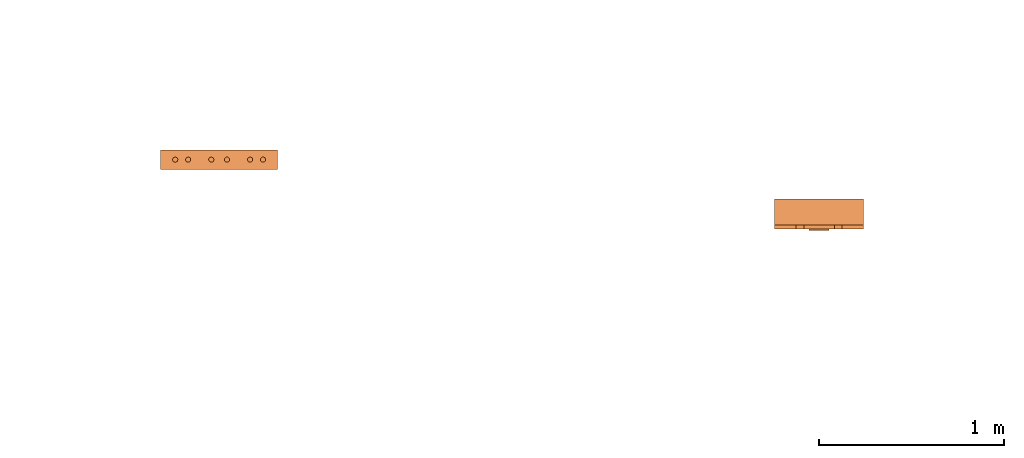
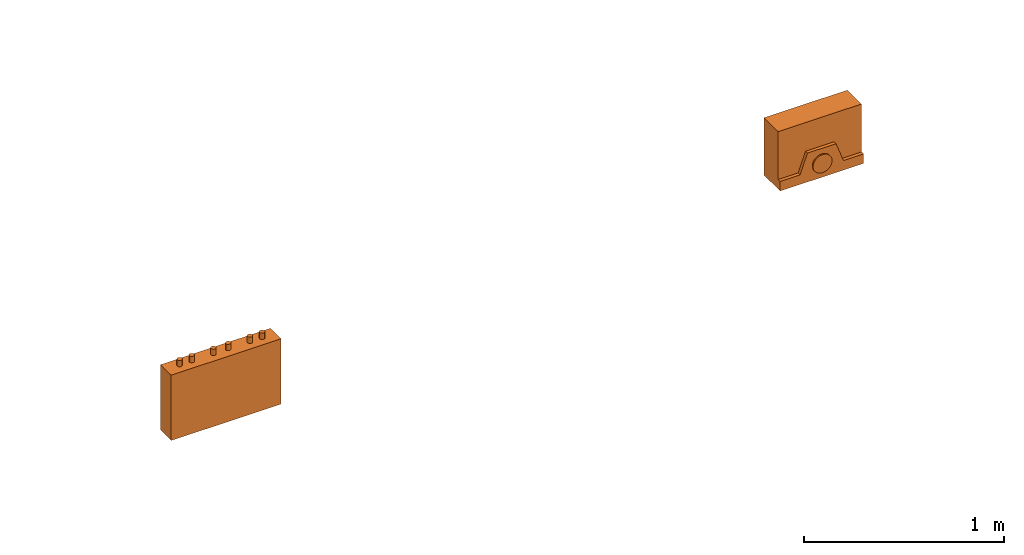
# One storey, part 3 of 5: 2 proxies.
"""IFC2X3 building model written with IfcOpenShell, lengths in millimetres."""

from ifc_helpers import new_model, entity, si_unit, converted_unit, derived_unit, direction, frame, origin, place, context, subcontext, project, spatial, faceted_brep, source, transform, mapped, material, material_list, type_object, type_shapes, element, save


model = new_model("IFC2X3")

# Units and contexts
model_context = context("Model", 3, precision=0.01, world=origin(), true_north=direction((6.12303176911189e-17, 1.0)))
body_context = subcontext(model_context, "Body", "Model", "MODEL_VIEW")
ifc_project = project(units=[si_unit("LENGTHUNIT", "METRE", prefix="MILLI"), si_unit("AREAUNIT", "SQUARE_METRE"), si_unit("VOLUMEUNIT", "CUBIC_METRE"), converted_unit("PLANEANGLEUNIT", "DEGREE", entity("IfcRatioMeasure", 0.0174532925199433), si_unit("PLANEANGLEUNIT", "RADIAN"), dimensions=[0, 0, 0, 0, 0, 0, 0]), si_unit("MASSUNIT", "GRAM", prefix="KILO"), derived_unit("MASSDENSITYUNIT", [(si_unit("MASSUNIT", "GRAM", prefix="KILO"), 1), (si_unit("LENGTHUNIT", "METRE"), -3)]), derived_unit("MOMENTOFINERTIAUNIT", [(si_unit("LENGTHUNIT", "METRE"), 4)]), si_unit("TIMEUNIT", "SECOND"), si_unit("FREQUENCYUNIT", "HERTZ"), si_unit("THERMODYNAMICTEMPERATUREUNIT", "DEGREE_CELSIUS"), derived_unit("THERMALTRANSMITTANCEUNIT", [(si_unit("MASSUNIT", "GRAM", prefix="KILO"), 1), (si_unit("THERMODYNAMICTEMPERATUREUNIT", "KELVIN"), -1), (si_unit("TIMEUNIT", "SECOND"), -3)]), derived_unit("VOLUMETRICFLOWRATEUNIT", [(si_unit("LENGTHUNIT", "METRE"), 3), (si_unit("TIMEUNIT", "SECOND"), -1)]), derived_unit("MASSFLOWRATEUNIT", [(si_unit("MASSUNIT", "GRAM", prefix="KILO"), 1), (si_unit("TIMEUNIT", "SECOND"), -1)]), derived_unit("ROTATIONALFREQUENCYUNIT", [(si_unit("TIMEUNIT", "SECOND"), -1)]), si_unit("ELECTRICCURRENTUNIT", "AMPERE"), si_unit("ELECTRICVOLTAGEUNIT", "VOLT"), si_unit("POWERUNIT", "WATT"), si_unit("FORCEUNIT", "NEWTON", prefix="KILO"), si_unit("ILLUMINANCEUNIT", "LUX"), si_unit("LUMINOUSFLUXUNIT", "LUMEN"), si_unit("LUMINOUSINTENSITYUNIT", "CANDELA"), derived_unit("USERDEFINED", [(si_unit("MASSUNIT", "GRAM", prefix="KILO"), -1), (si_unit("LENGTHUNIT", "METRE"), -2), (si_unit("TIMEUNIT", "SECOND"), 3), (si_unit("LUMINOUSFLUXUNIT", "LUMEN"), 1)]), derived_unit("LINEARVELOCITYUNIT", [(si_unit("LENGTHUNIT", "METRE"), 1), (si_unit("TIMEUNIT", "SECOND"), -1)]), si_unit("PRESSUREUNIT", "PASCAL"), derived_unit("USERDEFINED", [(si_unit("LENGTHUNIT", "METRE"), -2), (si_unit("MASSUNIT", "GRAM", prefix="KILO"), 1), (si_unit("TIMEUNIT", "SECOND"), -2)]), derived_unit("LINEARFORCEUNIT", [(si_unit("MASSUNIT", "GRAM", prefix="KILO"), 1), (si_unit("LENGTHUNIT", "METRE"), 1), (si_unit("TIMEUNIT", "SECOND"), -2), (si_unit("LENGTHUNIT", "METRE"), -1)]), derived_unit("PLANARFORCEUNIT", [(si_unit("MASSUNIT", "GRAM", prefix="KILO"), 1), (si_unit("LENGTHUNIT", "METRE"), 1), (si_unit("TIMEUNIT", "SECOND"), -2), (si_unit("LENGTHUNIT", "METRE"), -2)])], contexts=[model_context])

# Site, building, storey
site_placement = place(None, frame((0.0, 2493.83037508239, 0.0)))
site = spatial("IfcSite", under=ifc_project, at=site_placement, CompositionType="ELEMENT")
building_placement = place(site_placement, origin())
building = spatial("IfcBuilding", under=site, at=building_placement, CompositionType="ELEMENT")
storey_placement = place(building_placement, frame((0.0, 0.0, 19800.0)))
storey = spatial("IfcBuildingStorey", under=building, at=storey_placement, Name="06", CompositionType="ELEMENT", Elevation=19800.0)

# Proxies
ifc_material_1 = material()
ifc_material_2 = material()
ifc_material_list_1 = material_list([ifc_material_1, ifc_material_2])
building_element_proxy_type_1 = type_object("IfcBuildingElementProxyType", PredefinedType="NOTDEFINED", material=ifc_material_1)
shared_shape_1 = source(origin(), body_context, "Body", "Brep", [
    faceted_brep([(168.201612490282, 212.500000000001, 135.54049916809), (168.201612490282, 201.109127034741, 126.799974925206), (168.201612490282, 192.368602791857, 115.409101959946), (168.201612490282, 186.874079554102, 102.144149440585), (168.201612490282, 185.0, 87.9091019599461), (168.201612490282, 186.874079554102, 73.6740544793074), (168.201612490282, 192.368602791856, 60.4091019599461), (168.201612490282, 201.10912703474, 49.0182289946861), (168.201612490282, 212.500000000001, 40.2777047518019), (168.201612490282, 225.764952519362, 34.7831815140474), (168.201612490282, 240.0, 32.9091019599461), (168.201612490282, 254.235047480639, 34.7831815140472), (168.201612490282, 267.5, 40.2777047518019), (168.201612490282, 278.890872965261, 49.0182289946858), (168.201612490282, 287.631397208145, 60.4091019599458), (168.201612490282, 293.125920445899, 73.6740544793071), (168.201612490282, 295.0, 87.9091019599458), (168.201612490282, 293.125920445899, 102.144149440584), (168.201612490282, 287.631397208145, 115.409101959946), (168.201612490282, 278.890872965261, 126.799974925206), (168.201612490282, 267.500000000001, 135.54049916809), (168.201612490282, 254.235047480639, 141.035022405845), (168.201612490282, 240.0, 142.909101959946), (168.201612490282, 225.764952519362, 141.035022405845), (160.0, 225.764952519362, 34.7831815140474), (160.0, 212.500000000001, 40.2777047518019), (160.0, 201.10912703474, 49.0182289946861), (160.0, 192.368602791856, 60.4091019599461), (160.0, 186.874079554102, 73.6740544793074), (160.0, 185.0, 87.9091019599463), (160.0, 186.874079554102, 102.144149440585), (160.0, 192.368602791857, 115.409101959946), (160.0, 201.109127034741, 126.799974925206), (160.0, 212.500000000001, 135.54049916809), (160.0, 225.764952519362, 141.035022405845), (160.0, 240.0, 142.909101959946), (160.0, 254.235047480639, 141.035022405845), (160.0, 267.500000000001, 135.54049916809), (160.0, 278.890872965261, 126.799974925206), (160.0, 287.631397208145, 115.409101959946), (160.0, 293.125920445899, 102.144149440584), (160.0, 295.0, 87.9091019599458), (160.0, 293.125920445899, 73.6740544793071), (160.0, 287.631397208145, 60.4091019599458), (160.0, 278.890872965261, 49.0182289946858), (160.0, 267.5, 40.2777047518019), (160.0, 254.235047480639, 34.7831815140472), (160.0, 240.0, 32.9091019599461)], [[[0, 1, 2, 3, 4, 5, 6, 7, 8, 9, 10, 11, 12, 13, 14, 15, 16, 17, 18, 19, 20, 21, 22, 23]], [[24, 25, 26, 27, 28, 29, 30, 31, 32, 33, 34, 35, 36, 37, 38, 39, 40, 41, 42, 43, 44, 45, 46, 47]], [[40, 17, 16, 41]], [[39, 18, 17, 40]], [[20, 19, 38, 37]], [[39, 38, 19, 18]], [[21, 20, 37, 36]], [[22, 21, 36, 35]], [[34, 23, 22, 35]], [[33, 0, 23, 34]], [[2, 1, 32, 31]], [[33, 32, 1, 0]], [[3, 2, 31, 30]], [[4, 3, 30, 29]], [[28, 5, 4, 29]], [[27, 6, 5, 28]], [[8, 7, 26, 25]], [[27, 26, 7, 6]], [[9, 8, 25, 24]], [[10, 9, 24, 47]], [[46, 11, 10, 47]], [[45, 12, 11, 46]], [[14, 13, 44, 43]], [[45, 44, 13, 12]], [[15, 14, 43, 42]], [[16, 15, 42, 41]]]),
    faceted_brep([(160.0, 0.0, 0.0), (160.0, 480.0, 0.0), (160.0, 480.0, 58.2870579365997), (160.0, 365.0, 58.2870579366005), (160.0, 322.247482084292, 175.748635534839), (160.0, 157.75251791571, 175.748635534839), (160.0, 115.0, 58.2870579366), (160.0, 0.0, 58.2870579365997), (0.0, 480.0, 0.0), (0.0, 0.0, 0.0), (0.0, 0.0, 350.0), (0.0, 480.0, 350.0), (140.211167148102, 480.0, 350.0), (140.211167148102, 480.0, 58.2870579365997), (140.211167148102, 0.0, 350.0), (140.211167148102, 0.0, 58.2870579365997), (140.211167148102, 365.0, 58.2870579366), (140.211167148102, 115.0, 58.2870579366), (140.211167148102, 157.75251791571, 175.748635534839), (140.211167148102, 322.247482084292, 175.748635534839)], [[[0, 1, 2, 3, 4, 5, 6, 7]], [[8, 9, 10, 11]], [[8, 11, 12, 13, 2, 1]], [[11, 10, 14, 12]], [[10, 9, 0, 7, 15, 14]], [[1, 0, 9, 8]], [[16, 13, 12, 14, 15, 17, 18, 19]], [[13, 16, 3, 2]], [[17, 15, 7, 6]], [[18, 17, 6, 5]], [[19, 18, 5, 4]], [[16, 19, 4, 3]]]),
])
type_shapes(building_element_proxy_type_1, [shared_shape_1])
proxy_1_placement = place(storey_placement, frame((64290.1085349485, 4936.16962491763, 1500.0), z_axis=(0.0, 0.0, 1.0), x_axis=(0.0, -1.0, 0.0)))
element("IfcBuildingElementProxy", 1, at=proxy_1_placement, inside=storey, type_object=building_element_proxy_type_1, material=ifc_material_list_1, context=body_context, shape_type="MappedRepresentation", body=[
    mapped(shared_shape_1, transform((0.0, 0.0, 0.0), scale=1.0)),
])
ifc_material_3 = material()
ifc_material_list_2 = material_list([ifc_material_3, ifc_material_2])
building_element_proxy_type_2 = type_object("IfcBuildingElementProxyType", PredefinedType="NOTDEFINED", material=ifc_material_3)
shared_shape_2 = source(origin(), body_context, "Body", "Brep", [
    faceted_brep([(61.7366777047886, 89.258069163288, 398.0), (63.9615384211591, 86.3585742266764, 398.0), (65.3601443362239, 82.9820408581116, 398.0), (65.837182768177, 79.3585742266763, 398.0), (65.3601443362239, 75.735107595241, 398.0), (63.9615384211591, 72.3585742266763, 398.0), (61.7366777047886, 69.4590792900646, 398.0), (58.8371827681769, 67.2342185736942, 398.0), (55.4606493996122, 65.8356126586294, 398.0), (51.8371827681769, 65.3585742266764, 398.0), (48.2137161367416, 65.8356126586295, 398.0), (44.8371827681769, 67.2342185736943, 398.0), (41.9376878315653, 69.4590792900647, 398.0), (39.7128271151948, 72.3585742266764, 398.0), (38.31422120013, 75.7351075952411, 398.0), (37.837182768177, 79.3585742266764, 398.0), (38.31422120013, 82.9820408581117, 398.0), (39.7128271151949, 86.3585742266764, 398.0), (41.9376878315653, 89.258069163288, 398.0), (44.837182768177, 91.4829298796585, 398.0), (48.2137161367417, 92.8815357947233, 398.0), (51.837182768177, 93.3585742266764, 398.0), (55.4606493996123, 92.8815357947233, 398.0), (58.837182768177, 91.4829298796585, 398.0), (58.8371827681769, 67.2342185736942, 436.716690815491), (61.7366777047886, 69.4590792900646, 436.716690815491), (63.9615384211591, 72.3585742266763, 436.716690815491), (65.3601443362239, 75.735107595241, 436.716690815491), (65.837182768177, 79.3585742266764, 436.716690815491), (65.3601443362239, 82.9820408581116, 436.716690815491), (63.9615384211591, 86.3585742266764, 436.716690815491), (61.7366777047886, 89.258069163288, 436.716690815491), (58.837182768177, 91.4829298796585, 436.716690815491), (55.4606493996123, 92.8815357947233, 436.716690815491), (51.837182768177, 93.3585742266764, 436.716690815491), (48.2137161367417, 92.8815357947233, 436.716690815491), (44.837182768177, 91.4829298796585, 436.716690815491), (41.9376878315653, 89.258069163288, 436.716690815491), (39.7128271151949, 86.3585742266764, 436.716690815491), (38.31422120013, 82.9820408581117, 436.716690815491), (37.837182768177, 79.3585742266764, 436.716690815491), (38.31422120013, 75.7351075952411, 436.716690815491), (39.7128271151948, 72.3585742266764, 436.716690815491), (41.9376878315653, 69.4590792900647, 436.716690815491), (44.8371827681769, 67.2342185736943, 436.716690815491), (48.2137161367416, 65.8356126586295, 436.716690815491), (51.8371827681769, 65.3585742266764, 436.716690815491), (55.4606493996122, 65.8356126586294, 436.716690815491)], [[[0, 1, 2, 3, 4, 5, 6, 7, 8, 9, 10, 11, 12, 13, 14, 15, 16, 17, 18, 19, 20, 21, 22, 23]], [[24, 25, 26, 27, 28, 29, 30, 31, 32, 33, 34, 35, 36, 37, 38, 39, 40, 41, 42, 43, 44, 45, 46, 47]], [[40, 15, 14, 41]], [[13, 42, 41, 14]], [[43, 12, 11, 44]], [[13, 12, 43, 42]], [[44, 11, 10, 45]], [[9, 46, 45, 10]], [[47, 8, 7, 24]], [[6, 25, 24, 7]], [[26, 5, 4, 27]], [[6, 5, 26, 25]], [[27, 4, 3, 28]], [[47, 46, 9, 8]], [[1, 30, 29, 2]], [[0, 31, 30, 1]], [[22, 33, 32, 23]], [[23, 32, 31, 0]], [[21, 34, 33, 22]], [[28, 3, 2, 29]], [[35, 20, 19, 36]], [[18, 37, 36, 19]], [[38, 17, 16, 39]], [[18, 17, 38, 37]], [[39, 16, 15, 40]], [[35, 34, 21, 20]]]),
    faceted_brep([(58.837182768177, 542.517070120343, 436.716690815491), (61.7366777047886, 544.741930836713, 436.716690815491), (63.9615384211591, 547.641425773325, 436.716690815491), (65.360144336224, 551.017959141889, 436.716690815491), (65.837182768177, 554.641425773325, 436.716690815491), (65.360144336224, 558.26489240476, 436.716690815491), (63.9615384211592, 561.641425773325, 436.716690815491), (61.7366777047887, 564.540920709937, 436.716690815491), (58.8371827681771, 566.765781426307, 436.716690815491), (55.4606493996123, 568.164387341372, 436.716690815491), (51.8371827681771, 568.641425773325, 436.716690815491), (48.2137161367418, 568.164387341372, 436.716690815491), (44.8371827681771, 566.765781426307, 436.716690815491), (41.9376878315654, 564.540920709937, 436.716690815491), (39.7128271151949, 561.641425773325, 436.716690815491), (38.3142212001301, 558.26489240476, 436.716690815491), (37.837182768177, 554.641425773325, 436.716690815491), (38.3142212001301, 551.01795914189, 436.716690815491), (39.7128271151949, 547.641425773325, 436.716690815491), (41.9376878315653, 544.741930836713, 436.716690815491), (44.837182768177, 542.517070120343, 436.716690815491), (48.2137161367417, 541.118464205278, 436.716690815491), (51.837182768177, 540.641425773325, 436.716690815491), (55.4606493996123, 541.118464205278, 436.716690815491), (51.8371827681771, 568.641425773325, 398.0), (55.4606493996123, 568.164387341372, 398.0), (58.8371827681771, 566.765781426307, 398.0), (61.7366777047887, 564.540920709937, 398.0), (63.9615384211592, 561.641425773325, 398.0), (65.360144336224, 558.26489240476, 398.0), (65.837182768177, 554.641425773325, 398.0), (65.360144336224, 551.017959141889, 398.0), (63.9615384211591, 547.641425773325, 398.0), (61.7366777047886, 544.741930836713, 398.0), (58.837182768177, 542.517070120343, 398.0), (55.4606493996123, 541.118464205278, 398.0), (51.837182768177, 540.641425773325, 398.0), (48.2137161367417, 541.118464205278, 398.0), (44.837182768177, 542.517070120343, 398.0), (41.9376878315653, 544.741930836713, 398.0), (39.7128271151949, 547.641425773325, 398.0), (38.3142212001301, 551.01795914189, 398.0), (37.837182768177, 554.641425773325, 398.0), (38.3142212001301, 558.26489240476, 398.0), (39.7128271151949, 561.641425773325, 398.0), (41.9376878315654, 564.540920709937, 398.0), (44.8371827681771, 566.765781426307, 398.0), (48.2137161367418, 568.164387341372, 398.0)], [[[0, 1, 2, 3, 4, 5, 6, 7, 8, 9, 10, 11, 12, 13, 14, 15, 16, 17, 18, 19, 20, 21, 22, 23]], [[24, 25, 26, 27, 28, 29, 30, 31, 32, 33, 34, 35, 36, 37, 38, 39, 40, 41, 42, 43, 44, 45, 46, 47]], [[17, 41, 40, 18]], [[39, 19, 18, 40]], [[20, 38, 37, 21]], [[39, 38, 20, 19]], [[21, 37, 36, 22]], [[41, 17, 16, 42]], [[23, 35, 34, 0]], [[33, 1, 0, 34]], [[2, 32, 31, 3]], [[33, 32, 2, 1]], [[3, 31, 30, 4]], [[35, 23, 22, 36]], [[29, 5, 4, 30]], [[28, 6, 5, 29]], [[9, 25, 24, 10]], [[27, 7, 6, 28]], [[26, 8, 7, 27]], [[26, 25, 9, 8]], [[11, 47, 46, 12]], [[45, 13, 12, 46]], [[14, 44, 43, 15]], [[45, 44, 14, 13]], [[15, 43, 42, 16]], [[47, 11, 10, 24]]]),
    faceted_brep([(58.8371827681769, 472.517070120343, 436.716690815491), (61.7366777047886, 474.741930836713, 436.716690815491), (63.961538421159, 477.641425773325, 436.716690815491), (65.3601443362239, 481.017959141889, 436.716690815491), (65.8371827681769, 484.641425773325, 436.716690815491), (65.3601443362239, 488.26489240476, 436.716690815491), (63.9615384211591, 491.641425773325, 436.716690815491), (61.7366777047886, 494.540920709936, 436.716690815491), (58.837182768177, 496.765781426307, 436.716690815491), (55.4606493996123, 498.164387341372, 436.716690815491), (51.837182768177, 498.641425773325, 436.716690815491), (48.2137161367417, 498.164387341372, 436.716690815491), (44.837182768177, 496.765781426307, 436.716690815491), (41.9376878315653, 494.540920709937, 436.716690815491), (39.7128271151948, 491.641425773325, 436.716690815491), (38.31422120013, 488.26489240476, 436.716690815491), (37.837182768177, 484.641425773325, 436.716690815491), (38.31422120013, 481.01795914189, 436.716690815491), (39.7128271151948, 477.641425773325, 436.716690815491), (41.9376878315653, 474.741930836713, 436.716690815491), (44.8371827681769, 472.517070120343, 436.716690815491), (48.2137161367416, 471.118464205278, 436.716690815491), (51.8371827681769, 470.641425773325, 436.716690815491), (55.4606493996122, 471.118464205278, 436.716690815491), (51.837182768177, 498.641425773325, 398.0), (55.4606493996123, 498.164387341372, 398.0), (58.837182768177, 496.765781426307, 398.0), (61.7366777047886, 494.540920709936, 398.0), (63.9615384211591, 491.641425773325, 398.0), (65.3601443362239, 488.26489240476, 398.0), (65.8371827681769, 484.641425773325, 398.0), (65.3601443362239, 481.017959141889, 398.0), (63.961538421159, 477.641425773325, 398.0), (61.7366777047886, 474.741930836713, 398.0), (58.8371827681769, 472.517070120343, 398.0), (55.4606493996122, 471.118464205278, 398.0), (51.8371827681769, 470.641425773325, 398.0), (48.2137161367416, 471.118464205278, 398.0), (44.8371827681769, 472.517070120343, 398.0), (41.9376878315653, 474.741930836713, 398.0), (39.7128271151948, 477.641425773325, 398.0), (38.31422120013, 481.01795914189, 398.0), (37.837182768177, 484.641425773325, 398.0), (38.31422120013, 488.26489240476, 398.0), (39.7128271151948, 491.641425773325, 398.0), (41.9376878315653, 494.540920709937, 398.0), (44.837182768177, 496.765781426307, 398.0), (48.2137161367417, 498.164387341372, 398.0)], [[[0, 1, 2, 3, 4, 5, 6, 7, 8, 9, 10, 11, 12, 13, 14, 15, 16, 17, 18, 19, 20, 21, 22, 23]], [[24, 25, 26, 27, 28, 29, 30, 31, 32, 33, 34, 35, 36, 37, 38, 39, 40, 41, 42, 43, 44, 45, 46, 47]], [[16, 42, 41, 17]], [[40, 18, 17, 41]], [[19, 39, 38, 20]], [[40, 39, 19, 18]], [[20, 38, 37, 21]], [[36, 22, 21, 37]], [[23, 35, 34, 0]], [[33, 1, 0, 34]], [[2, 32, 31, 3]], [[33, 32, 2, 1]], [[3, 31, 30, 4]], [[23, 22, 36, 35]], [[28, 6, 5, 29]], [[27, 7, 6, 28]], [[25, 9, 8, 26]], [[26, 8, 7, 27]], [[24, 10, 9, 25]], [[4, 30, 29, 5]], [[11, 47, 46, 12]], [[45, 13, 12, 46]], [[14, 44, 43, 15]], [[45, 44, 14, 13]], [[15, 43, 42, 16]], [[11, 10, 24, 47]]]),
    faceted_brep([(58.8371827681766, 347.517070120343, 436.716690815491), (61.7366777047883, 349.741930836713, 436.716690815491), (63.9615384211588, 352.641425773325, 436.716690815491), (65.3601443362236, 356.017959141889, 436.716690815491), (65.8371827681767, 359.641425773325, 436.716690815491), (65.3601443362237, 363.26489240476, 436.716690815491), (63.9615384211589, 366.641425773325, 436.716690815491), (61.7366777047884, 369.540920709937, 436.716690815491), (58.8371827681767, 371.765781426307, 436.716690815491), (55.460649399612, 373.164387341372, 436.716690815491), (51.8371827681767, 373.641425773325, 436.716690815491), (48.2137161367414, 373.164387341372, 436.716690815491), (44.8371827681767, 371.765781426307, 436.716690815491), (41.9376878315651, 369.540920709937, 436.716690815491), (39.7128271151946, 366.641425773325, 436.716690815491), (38.3142212001298, 363.26489240476, 436.716690815491), (37.8371827681767, 359.641425773325, 436.716690815491), (38.3142212001298, 356.01795914189, 436.716690815491), (39.7128271151945, 352.641425773325, 436.716690815491), (41.937687831565, 349.741930836713, 436.716690815491), (44.8371827681767, 347.517070120343, 436.716690815491), (48.2137161367414, 346.118464205278, 436.716690815491), (51.8371827681766, 345.641425773325, 436.716690815491), (55.4606493996119, 346.118464205278, 436.716690815491), (51.8371827681767, 373.641425773325, 398.0), (55.460649399612, 373.164387341372, 398.0), (58.8371827681767, 371.765781426307, 398.0), (61.7366777047884, 369.540920709937, 398.0), (63.9615384211589, 366.641425773325, 398.0), (65.3601443362237, 363.26489240476, 398.0), (65.8371827681767, 359.641425773325, 398.0), (65.3601443362236, 356.017959141889, 398.0), (63.9615384211588, 352.641425773325, 398.0), (61.7366777047883, 349.741930836713, 398.0), (58.8371827681766, 347.517070120343, 398.0), (55.4606493996119, 346.118464205278, 398.0), (51.8371827681766, 345.641425773325, 398.0), (48.2137161367414, 346.118464205278, 398.0), (44.8371827681767, 347.517070120343, 398.0), (41.937687831565, 349.741930836713, 398.0), (39.7128271151945, 352.641425773325, 398.0), (38.3142212001298, 356.01795914189, 398.0), (37.8371827681767, 359.641425773325, 398.0), (38.3142212001298, 363.26489240476, 398.0), (39.7128271151946, 366.641425773325, 398.0), (41.9376878315651, 369.540920709937, 398.0), (44.8371827681767, 371.765781426307, 398.0), (48.2137161367414, 373.164387341372, 398.0)], [[[0, 1, 2, 3, 4, 5, 6, 7, 8, 9, 10, 11, 12, 13, 14, 15, 16, 17, 18, 19, 20, 21, 22, 23]], [[24, 25, 26, 27, 28, 29, 30, 31, 32, 33, 34, 35, 36, 37, 38, 39, 40, 41, 42, 43, 44, 45, 46, 47]], [[16, 42, 41, 17]], [[40, 18, 17, 41]], [[19, 39, 38, 20]], [[40, 39, 19, 18]], [[20, 38, 37, 21]], [[36, 22, 21, 37]], [[23, 35, 34, 0]], [[33, 1, 0, 34]], [[2, 32, 31, 3]], [[33, 32, 2, 1]], [[3, 31, 30, 4]], [[23, 22, 36, 35]], [[28, 6, 5, 29]], [[27, 7, 6, 28]], [[25, 9, 8, 26]], [[26, 8, 7, 27]], [[24, 10, 9, 25]], [[4, 30, 29, 5]], [[11, 47, 46, 12]], [[45, 13, 12, 46]], [[14, 44, 43, 15]], [[45, 44, 14, 13]], [[15, 43, 42, 16]], [[11, 10, 24, 47]]]),
    faceted_brep([(58.8371827681766, 262.234218573694, 436.716690815491), (61.7366777047883, 264.459079290065, 436.716690815491), (63.9615384211588, 267.358574226676, 436.716690815491), (65.3601443362236, 270.735107595241, 436.716690815491), (65.8371827681767, 274.358574226676, 436.716690815491), (65.3601443362237, 277.982040858112, 436.716690815491), (63.9615384211588, 281.358574226676, 436.716690815491), (61.7366777047884, 284.258069163288, 436.716690815491), (58.8371827681767, 286.482929879658, 436.716690815491), (55.460649399612, 287.881535794723, 436.716690815491), (51.8371827681767, 288.358574226676, 436.716690815491), (48.2137161367414, 287.881535794723, 436.716690815491), (44.8371827681767, 286.482929879659, 436.716690815491), (41.9376878315651, 284.258069163288, 436.716690815491), (39.7128271151946, 281.358574226676, 436.716690815491), (38.3142212001298, 277.982040858112, 436.716690815491), (37.8371827681767, 274.358574226676, 436.716690815491), (38.3142212001297, 270.735107595241, 436.716690815491), (39.7128271151945, 267.358574226676, 436.716690815491), (41.937687831565, 264.459079290065, 436.716690815491), (44.8371827681767, 262.234218573694, 436.716690815491), (48.2137161367414, 260.835612658629, 436.716690815491), (51.8371827681766, 260.358574226676, 436.716690815491), (55.4606493996119, 260.835612658629, 436.716690815491), (51.8371827681767, 288.358574226676, 398.0), (55.460649399612, 287.881535794723, 398.0), (58.8371827681767, 286.482929879658, 398.0), (61.7366777047884, 284.258069163288, 398.0), (63.9615384211588, 281.358574226676, 398.0), (65.3601443362237, 277.982040858112, 398.0), (65.8371827681767, 274.358574226676, 398.0), (65.3601443362236, 270.735107595241, 398.0), (63.9615384211588, 267.358574226676, 398.0), (61.7366777047883, 264.459079290065, 398.0), (58.8371827681766, 262.234218573694, 398.0), (55.4606493996119, 260.835612658629, 398.0), (51.8371827681766, 260.358574226676, 398.0), (48.2137161367414, 260.835612658629, 398.0), (44.8371827681767, 262.234218573694, 398.0), (41.937687831565, 264.459079290065, 398.0), (39.7128271151945, 267.358574226676, 398.0), (38.3142212001297, 270.735107595241, 398.0), (37.8371827681767, 274.358574226676, 398.0), (38.3142212001298, 277.982040858112, 398.0), (39.7128271151946, 281.358574226676, 398.0), (41.9376878315651, 284.258069163288, 398.0), (44.8371827681767, 286.482929879659, 398.0), (48.2137161367414, 287.881535794723, 398.0)], [[[0, 1, 2, 3, 4, 5, 6, 7, 8, 9, 10, 11, 12, 13, 14, 15, 16, 17, 18, 19, 20, 21, 22, 23]], [[24, 25, 26, 27, 28, 29, 30, 31, 32, 33, 34, 35, 36, 37, 38, 39, 40, 41, 42, 43, 44, 45, 46, 47]], [[16, 42, 41, 17]], [[40, 18, 17, 41]], [[19, 39, 38, 20]], [[40, 39, 19, 18]], [[20, 38, 37, 21]], [[36, 22, 21, 37]], [[23, 35, 34, 0]], [[33, 1, 0, 34]], [[2, 32, 31, 3]], [[33, 32, 2, 1]], [[3, 31, 30, 4]], [[23, 22, 36, 35]], [[4, 30, 29, 5]], [[28, 6, 5, 29]], [[7, 27, 26, 8]], [[28, 27, 7, 6]], [[8, 26, 25, 9]], [[24, 10, 9, 25]], [[11, 47, 46, 12]], [[45, 13, 12, 46]], [[14, 44, 43, 15]], [[45, 44, 14, 13]], [[15, 43, 42, 16]], [[11, 10, 24, 47]]]),
    faceted_brep([(58.8371827681768, 137.234218573694, 436.716690815491), (61.7366777047885, 139.459079290065, 436.716690815491), (63.961538421159, 142.358574226676, 436.716690815491), (65.3601443362238, 145.735107595241, 436.716690815491), (65.8371827681769, 149.358574226676, 436.716690815491), (65.3601443362239, 152.982040858112, 436.716690815491), (63.961538421159, 156.358574226676, 436.716690815491), (61.7366777047886, 159.258069163288, 436.716690815491), (58.8371827681769, 161.482929879659, 436.716690815491), (55.4606493996122, 162.881535794723, 436.716690815491), (51.8371827681769, 163.358574226676, 436.716690815491), (48.2137161367416, 162.881535794723, 436.716690815491), (44.8371827681769, 161.482929879659, 436.716690815491), (41.9376878315653, 159.258069163288, 436.716690815491), (39.7128271151948, 156.358574226676, 436.716690815491), (38.31422120013, 152.982040858112, 436.716690815491), (37.8371827681769, 149.358574226676, 436.716690815491), (38.3142212001299, 145.735107595241, 436.716690815491), (39.7128271151947, 142.358574226676, 436.716690815491), (41.9376878315652, 139.459079290065, 436.716690815491), (44.8371827681769, 137.234218573694, 436.716690815491), (48.2137161367416, 135.83561265863, 436.716690815491), (51.8371827681768, 135.358574226676, 436.716690815491), (55.4606493996121, 135.835612658629, 436.716690815491), (61.7366777047886, 159.258069163288, 398.0), (63.961538421159, 156.358574226676, 398.0), (65.3601443362239, 152.982040858112, 398.0), (65.8371827681769, 149.358574226676, 398.0), (65.3601443362238, 145.735107595241, 398.0), (63.961538421159, 142.358574226676, 398.0), (61.7366777047885, 139.459079290065, 398.0), (58.8371827681768, 137.234218573694, 398.0), (55.4606493996121, 135.835612658629, 398.0), (51.8371827681768, 135.358574226676, 398.0), (48.2137161367416, 135.83561265863, 398.0), (44.8371827681769, 137.234218573694, 398.0), (41.9376878315652, 139.459079290065, 398.0), (39.7128271151947, 142.358574226676, 398.0), (38.3142212001299, 145.735107595241, 398.0), (37.8371827681769, 149.358574226676, 398.0), (38.31422120013, 152.982040858112, 398.0), (39.7128271151948, 156.358574226676, 398.0), (41.9376878315653, 159.258069163288, 398.0), (44.8371827681769, 161.482929879659, 398.0), (48.2137161367416, 162.881535794723, 398.0), (51.8371827681769, 163.358574226676, 398.0), (55.4606493996122, 162.881535794723, 398.0), (58.8371827681769, 161.482929879659, 398.0)], [[[0, 1, 2, 3, 4, 5, 6, 7, 8, 9, 10, 11, 12, 13, 14, 15, 16, 17, 18, 19, 20, 21, 22, 23]], [[24, 25, 26, 27, 28, 29, 30, 31, 32, 33, 34, 35, 36, 37, 38, 39, 40, 41, 42, 43, 44, 45, 46, 47]], [[16, 39, 38, 17]], [[37, 18, 17, 38]], [[19, 36, 35, 20]], [[37, 36, 19, 18]], [[20, 35, 34, 21]], [[33, 22, 21, 34]], [[23, 32, 31, 0]], [[30, 1, 0, 31]], [[2, 29, 28, 3]], [[30, 29, 2, 1]], [[3, 28, 27, 4]], [[23, 22, 33, 32]], [[25, 6, 5, 26]], [[24, 7, 6, 25]], [[46, 9, 8, 47]], [[47, 8, 7, 24]], [[45, 10, 9, 46]], [[4, 27, 26, 5]], [[11, 44, 43, 12]], [[42, 13, 12, 43]], [[14, 41, 40, 15]], [[42, 41, 14, 13]], [[15, 40, 39, 16]], [[11, 10, 45, 44]]]),
    faceted_brep([(106.0, 0.0, 0.0), (106.0, 634.0, 0.0), (106.0, 634.0, 398.0), (106.0, 0.0, 398.0), (0.0, 634.0, 398.0), (0.0, 524.500000000001, 254.822902819641), (0.0, 518.470476127564, 257.320413382257), (0.0, 529.677669529664, 250.849937254693), (0.0, 512.0, 258.17226772503), (0.0, 122.0, 258.17226772503), (0.0, 533.650635094612, 245.672267725029), (0.0, 536.148145657227, 239.642743852593), (0.0, 537.0, 233.17226772503), (0.0, 634.0, 0.0), (0.0, 0.0, 398.0), (0.0, 537.0, 143.17226772503), (0.0, 536.148145657227, 136.701791597467), (0.0, 533.650635094611, 130.67226772503), (0.0, 529.677669529664, 125.494598195366), (0.0, 524.5, 121.521632630419), (0.0, 518.470476127563, 119.024122067803), (0.0, 512.0, 118.17226772503), (0.0, 122.0, 118.172267725031), (0.0, 0.0, 0.0), (0.0, 97.0, 233.17226772503), (0.0, 115.529523872437, 119.024122067805), (0.0, 109.5, 121.521632630421), (0.0, 104.322330470337, 125.494598195368), (0.0, 100.349364905389, 130.672267725032), (0.0, 97.8518543427736, 136.701791597469), (0.0, 97.0, 143.172267725033), (0.0, 97.8518543427739, 239.642743852593), (0.0, 115.529523872438, 257.320413382257), (0.0, 109.500000000001, 254.822902819641), (0.0, 104.322330470337, 250.849937254693), (0.0, 100.34936490539, 245.67226772503), (16.2395209800454, 533.650635094612, 245.672267725029), (16.2395209800454, 536.148145657227, 239.642743852593), (16.2395209800454, 537.0, 233.17226772503), (16.2395209800454, 537.0, 143.17226772503), (16.2395209800454, 536.148145657227, 136.701791597467), (16.2395209800454, 533.650635094611, 130.67226772503), (16.2395209800454, 529.677669529664, 125.494598195366), (16.2395209800454, 524.5, 121.521632630419), (16.2395209800454, 518.470476127563, 119.024122067803), (16.2395209800454, 512.0, 118.17226772503), (16.2395209800454, 122.0, 118.172267725032), (16.2395209800454, 115.529523872437, 119.024122067805), (16.2395209800454, 109.5, 121.521632630421), (16.2395209800454, 104.322330470337, 125.494598195368), (16.2395209800454, 100.349364905389, 130.672267725032), (16.2395209800454, 97.8518543427736, 136.701791597469), (16.2395209800454, 97.0, 143.172267725032), (16.2395209800454, 97.0, 233.17226772503), (16.2395209800454, 97.8518543427739, 239.642743852593), (16.2395209800454, 100.34936490539, 245.67226772503), (16.2395209800454, 104.322330470337, 250.849937254694), (16.2395209800454, 109.500000000001, 254.822902819641), (16.2395209800454, 115.529523872438, 257.320413382257), (16.2395209800454, 122.0, 258.17226772503), (16.2395209800454, 512.0, 258.17226772503), (16.2395209800454, 518.470476127564, 257.320413382257), (16.2395209800454, 524.500000000001, 254.822902819641), (16.2395209800454, 529.677669529664, 250.849937254693)], [[[0, 1, 2, 3]], [[4, 5, 6]], [[5, 4, 7]], [[6, 8, 4]], [[4, 8, 9]], [[10, 7, 4]], [[11, 10, 4]], [[12, 11, 4]], [[4, 13, 12]], [[9, 14, 4]], [[15, 12, 13]], [[16, 15, 13]], [[16, 13, 17]], [[18, 17, 13]], [[13, 19, 18]], [[19, 13, 20]], [[21, 20, 13]], [[13, 22, 21]], [[22, 13, 23]], [[14, 24, 23]], [[25, 22, 23]], [[23, 26, 25]], [[26, 23, 27]], [[28, 27, 23]], [[28, 23, 29]], [[30, 29, 23]], [[30, 23, 24]], [[31, 24, 14]], [[9, 32, 14]], [[33, 14, 32]], [[14, 33, 34]], [[34, 35, 14]], [[35, 31, 14]], [[2, 1, 13, 4]], [[3, 2, 4, 14]], [[0, 3, 14, 23]], [[1, 0, 23, 13]], [[36, 37, 38, 39, 40, 41, 42, 43, 44, 45, 46, 47, 48, 49, 50, 51, 52, 53, 54, 55, 56, 57, 58, 59, 60, 61, 62, 63]], [[9, 8, 60, 59]], [[32, 9, 59, 58]], [[33, 32, 58, 57]], [[33, 57, 56, 34]], [[35, 34, 56, 55]], [[31, 35, 55, 54]], [[31, 54, 53, 24]], [[24, 53, 52, 30]], [[29, 30, 52, 51]], [[28, 29, 51, 50]], [[28, 50, 49, 27]], [[26, 27, 49, 48]], [[25, 26, 48, 47]], [[25, 47, 46, 22]], [[22, 46, 45, 21]], [[20, 21, 45, 44]], [[19, 20, 44, 43]], [[19, 43, 42, 18]], [[17, 18, 42, 41]], [[16, 17, 41, 40]], [[16, 40, 39, 15]], [[15, 39, 38, 12]], [[11, 12, 38, 37]], [[10, 11, 37, 36]], [[10, 36, 63, 7]], [[5, 7, 63, 62]], [[6, 5, 62, 61]], [[6, 61, 60, 8]]]),
])
type_shapes(building_element_proxy_type_2, [shared_shape_2])
proxy_2_placement = place(storey_placement, frame((60966.4005160432, 5202.16962491762, 950.0), z_axis=(0.0, 0.0, 1.0), x_axis=(0.0, -1.0, 0.0)))
element("IfcBuildingElementProxy", 2, at=proxy_2_placement, inside=storey, type_object=building_element_proxy_type_2, material=ifc_material_list_2, context=body_context, shape_type="MappedRepresentation", body=[
    mapped(shared_shape_2, transform((0.0, 0.0, 0.0), scale=1.0)),
])

save(model, "model.ifc")
